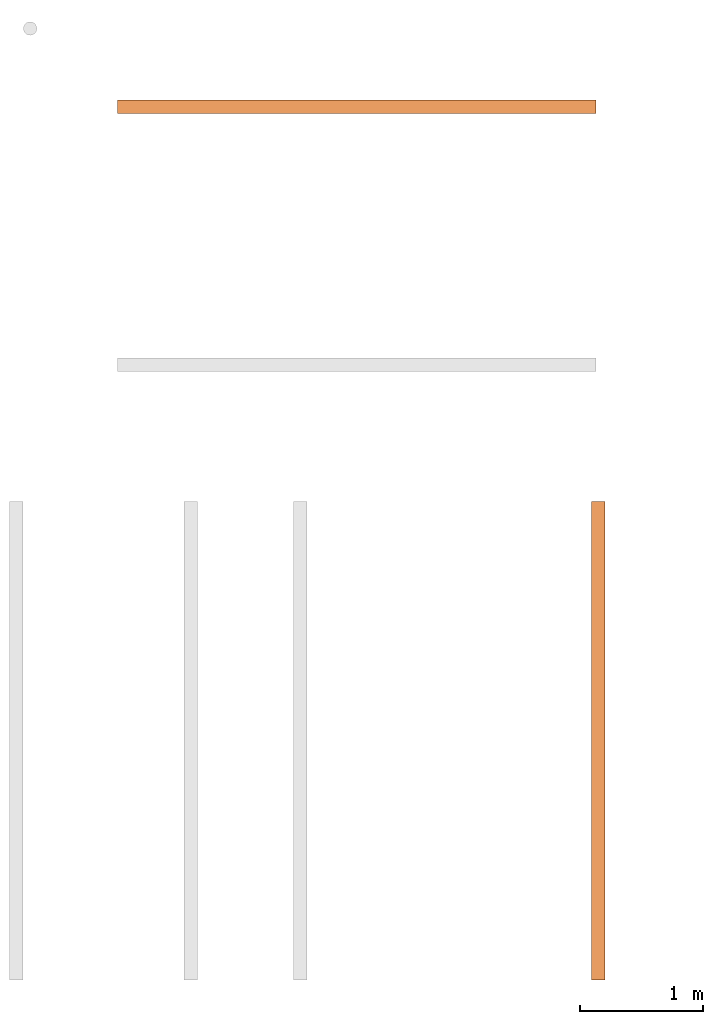
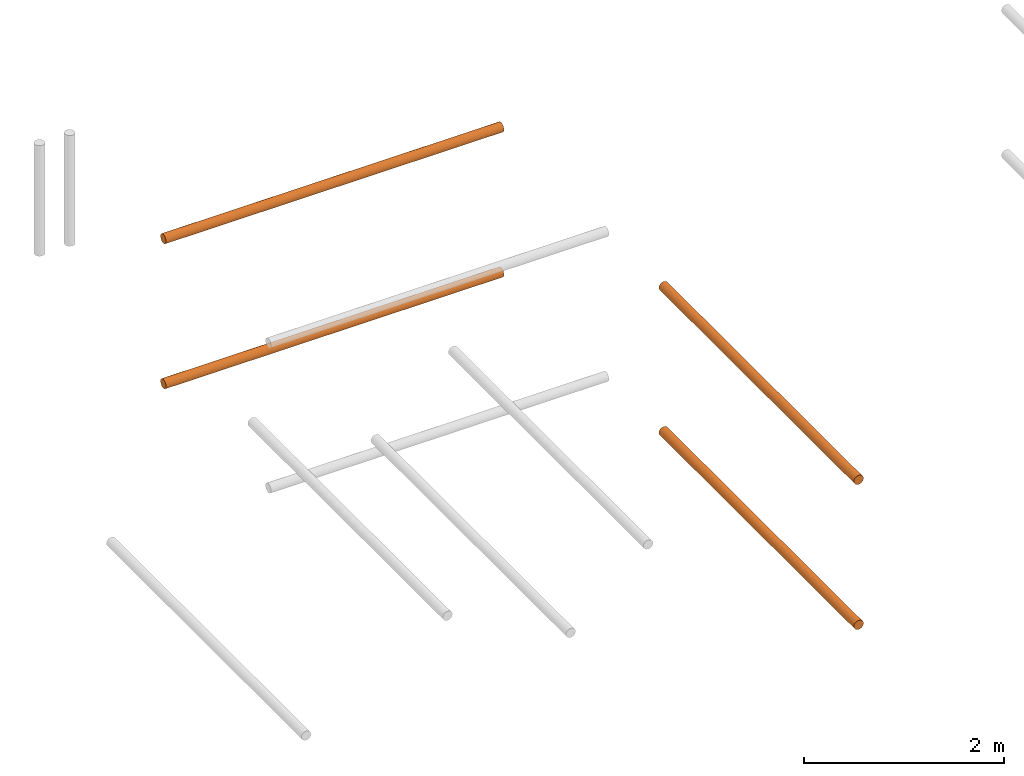
# One storey, part 4 of 5: 4 proxies.
"""IFC2X3 building model written with IfcOpenShell, lengths in metres."""

from ifc_helpers import new_model, entity, si_unit, converted_unit, frame, origin, place, context, subcontext, project, spatial, faceted_brep, material, element, save


model = new_model("IFC2X3")

# Units and contexts
model_context = context("Model", 3, precision=1e-05, world=origin())
body_context = subcontext(model_context, "Body", "Model", "MODEL_VIEW")
ifc_project = project(units=[si_unit("LENGTHUNIT", "METRE"), si_unit("AREAUNIT", "SQUARE_METRE"), si_unit("VOLUMEUNIT", "CUBIC_METRE"), converted_unit("PLANEANGLEUNIT", "DEGREE", entity("IfcPlaneAngleMeasure", 0.0174532925199433), si_unit("PLANEANGLEUNIT", "RADIAN"), dimensions=[0, 0, 0, 0, 0, 0, 0])], contexts=[model_context])

# Site, building, storey
site_placement = place(None, frame((2.0, 7.0, 6.0)))
site = spatial("IfcSite", under=ifc_project, at=site_placement, CompositionType="ELEMENT")
building_placement = place(site_placement, origin())
building = spatial("IfcBuilding", under=site, at=building_placement, Name="de", CompositionType="ELEMENT")
storey_placement = place(building_placement, frame((0.0, 0.0, 4.0)))
storey = spatial("IfcBuildingStorey", under=building, at=storey_placement, CompositionType="ELEMENT", Elevation=4.0)

# Proxies
ifc_material_1 = material()
proxy_1_placement = place(storey_placement, frame((2.371390691454128, 2.273736754432321e-16, 2.833089238362359)))
element("IfcBuildingElementProxy", 1, at=proxy_1_placement, inside=storey, material=ifc_material_1, context=body_context, shape_type="Brep", body=[
    faceted_brep([(0.11, 0.0, 0.05500000000000001), (0.1081259204458988, 0.0, 0.04076495251936138), (0.1026313972081441, 0.0, 0.02750000000000001), (0.09389087296526015, 0.0, 0.01610912703473991), (0.08250000000000002, 0.0, 0.007368602791855885), (0.06923504748063866, 0.0, 0.00187407955410125), (0.05500000000000003, 0.0, 0.0), (0.0407649525193614, 0.0, 0.001874079554101236), (0.02750000000000004, 0.0, 0.007368602791855849), (0.01610912703473991, 0.0, 0.01610912703473987), (0.007368602791855913, 0.0, 0.02749999999999994), (0.001874079554101257, 0.0, 0.04076495251936132), (0.0, 0.0, 0.05499999999999995), (0.001874079554101236, 0.0, 0.06923504748063862), (0.007368602791855849, 0.0, 0.08249999999999996), (0.01610912703473984, 0.0, 0.09389087296526008), (0.02749999999999994, 0.0, 0.1026313972081441), (0.04076495251936132, 0.0, 0.1081259204458988), (0.055, 0.0, 0.11), (0.06923504748063865, 0.0, 0.1081259204458988), (0.0825, 0.0, 0.1026313972081441), (0.09389087296526012, 0.0, 0.09389087296526012), (0.1026313972081441, 0.0, 0.0825), (0.1081259204458988, 0.0, 0.06923504748063866), (0.11, 3.9, 0.055), (0.1081259204458988, 3.9, 0.06923504748063866), (0.1026313972081441, 3.9, 0.0825), (0.09389087296526012, 3.9, 0.09389087296526012), (0.0825, 3.9, 0.1026313972081441), (0.06923504748063865, 3.9, 0.1081259204458988), (0.055, 3.9, 0.11), (0.04076495251936132, 3.9, 0.1081259204458988), (0.02749999999999994, 3.9, 0.1026313972081441), (0.01610912703473984, 3.9, 0.09389087296526008), (0.007368602791855849, 3.9, 0.08249999999999996), (0.001874079554101236, 3.9, 0.06923504748063862), (0.0, 3.9, 0.05499999999999995), (0.001874079554101257, 3.9, 0.04076495251936132), (0.007368602791855913, 3.9, 0.02749999999999994), (0.01610912703473991, 3.9, 0.01610912703473987), (0.02750000000000004, 3.9, 0.007368602791855849), (0.0407649525193614, 3.9, 0.001874079554101236), (0.05500000000000003, 3.9, 0.0), (0.06923504748063866, 3.9, 0.00187407955410125), (0.08250000000000002, 3.9, 0.007368602791855885), (0.09389087296526015, 3.9, 0.01610912703473991), (0.1026313972081441, 3.9, 0.02750000000000001), (0.1081259204458988, 3.9, 0.04076495251936138), (0.055, 3.9, 0.11), (0.055, 0.0, 0.11), (0.04076495251936132, 0.0, 0.1081259204458988), (0.04076495251936132, 3.9, 0.1081259204458988), (0.04076495251936132, 3.9, 0.1081259204458988), (0.04076495251936132, 0.0, 0.1081259204458988), (0.02749999999999994, 0.0, 0.1026313972081441), (0.02749999999999994, 3.9, 0.1026313972081441), (0.02749999999999994, 3.9, 0.1026313972081441), (0.02749999999999994, 0.0, 0.1026313972081441), (0.01610912703473984, 0.0, 0.09389087296526008), (0.01610912703473984, 3.9, 0.09389087296526008), (0.01610912703473984, 3.9, 0.09389087296526008), (0.01610912703473984, 0.0, 0.09389087296526008), (0.007368602791855849, 0.0, 0.08249999999999996), (0.007368602791855849, 3.9, 0.08249999999999996), (0.007368602791855849, 3.9, 0.08249999999999996), (0.007368602791855849, 0.0, 0.08249999999999996), (0.001874079554101236, 0.0, 0.06923504748063862), (0.001874079554101236, 3.9, 0.06923504748063862), (0.001874079554101236, 3.9, 0.06923504748063862), (0.001874079554101236, 0.0, 0.06923504748063862), (0.0, 0.0, 0.05499999999999995), (0.0, 3.9, 0.05499999999999995), (0.0, 3.9, 0.05499999999999995), (0.0, 0.0, 0.05499999999999995), (0.001874079554101257, 0.0, 0.04076495251936132), (0.001874079554101257, 3.9, 0.04076495251936132), (0.001874079554101257, 3.9, 0.04076495251936132), (0.001874079554101257, 0.0, 0.04076495251936132), (0.007368602791855913, 0.0, 0.02749999999999994), (0.007368602791855913, 3.9, 0.02749999999999994), (0.007368602791855913, 3.9, 0.02749999999999994), (0.007368602791855913, 0.0, 0.02749999999999994), (0.01610912703473991, 0.0, 0.01610912703473987), (0.01610912703473991, 3.9, 0.01610912703473987), (0.01610912703473991, 3.9, 0.01610912703473987), (0.01610912703473991, 0.0, 0.01610912703473987), (0.02750000000000004, 0.0, 0.007368602791855849), (0.02750000000000004, 3.9, 0.007368602791855849), (0.02750000000000004, 3.9, 0.007368602791855849), (0.02750000000000004, 0.0, 0.007368602791855849), (0.0407649525193614, 0.0, 0.001874079554101236), (0.0407649525193614, 3.9, 0.001874079554101236), (0.0407649525193614, 3.9, 0.001874079554101236), (0.0407649525193614, 0.0, 0.001874079554101236), (0.05500000000000003, 0.0, 0.0), (0.05500000000000003, 3.9, 0.0), (0.05500000000000003, 3.9, 0.0), (0.05500000000000003, 0.0, 0.0), (0.06923504748063866, 0.0, 0.00187407955410125), (0.06923504748063866, 3.9, 0.00187407955410125), (0.06923504748063866, 3.9, 0.00187407955410125), (0.06923504748063866, 0.0, 0.00187407955410125), (0.08250000000000002, 0.0, 0.007368602791855885), (0.08250000000000002, 3.9, 0.007368602791855885), (0.08250000000000002, 3.9, 0.007368602791855885), (0.08250000000000002, 0.0, 0.007368602791855885), (0.09389087296526015, 0.0, 0.01610912703473991), (0.09389087296526015, 3.9, 0.01610912703473991), (0.09389087296526015, 3.9, 0.01610912703473991), (0.09389087296526015, 0.0, 0.01610912703473991), (0.1026313972081441, 0.0, 0.02750000000000001), (0.1026313972081441, 3.9, 0.02750000000000001), (0.1026313972081441, 3.9, 0.02750000000000001), (0.1026313972081441, 0.0, 0.02750000000000001), (0.1081259204458988, 0.0, 0.04076495251936138), (0.1081259204458988, 3.9, 0.04076495251936138), (0.1081259204458988, 3.9, 0.04076495251936138), (0.1081259204458988, 0.0, 0.04076495251936138), (0.11, 0.0, 0.05500000000000001), (0.11, 3.9, 0.055), (0.11, 3.9, 0.055), (0.11, 0.0, 0.05500000000000001), (0.1081259204458988, 0.0, 0.06923504748063866), (0.1081259204458988, 3.9, 0.06923504748063866), (0.1081259204458988, 3.9, 0.06923504748063866), (0.1081259204458988, 0.0, 0.06923504748063866), (0.1026313972081441, 0.0, 0.0825), (0.1026313972081441, 3.9, 0.0825), (0.1026313972081441, 3.9, 0.0825), (0.1026313972081441, 0.0, 0.0825), (0.09389087296526012, 0.0, 0.09389087296526012), (0.09389087296526012, 3.9, 0.09389087296526012), (0.09389087296526012, 3.9, 0.09389087296526012), (0.09389087296526012, 0.0, 0.09389087296526012), (0.0825, 0.0, 0.1026313972081441), (0.0825, 3.9, 0.1026313972081441), (0.0825, 3.9, 0.1026313972081441), (0.0825, 0.0, 0.1026313972081441), (0.06923504748063865, 0.0, 0.1081259204458988), (0.06923504748063865, 3.9, 0.1081259204458988), (0.06923504748063865, 3.9, 0.1081259204458988), (0.06923504748063865, 0.0, 0.1081259204458988), (0.055, 0.0, 0.11), (0.055, 3.9, 0.11)], [[[0, 1, 2, 3, 4, 5, 6, 7, 8, 9, 10, 11, 12, 13, 14, 15, 16, 17, 18, 19, 20, 21, 22, 23]], [[24, 25, 26, 27, 28, 29, 30, 31, 32, 33, 34, 35, 36, 37, 38, 39, 40, 41, 42, 43, 44, 45, 46, 47]], [[48, 49, 50, 51]], [[52, 53, 54, 55]], [[56, 57, 58, 59]], [[60, 61, 62, 63]], [[64, 65, 66, 67]], [[68, 69, 70, 71]], [[72, 73, 74, 75]], [[76, 77, 78, 79]], [[80, 81, 82, 83]], [[84, 85, 86, 87]], [[88, 89, 90, 91]], [[92, 93, 94, 95]], [[96, 97, 98, 99]], [[100, 101, 102, 103]], [[104, 105, 106, 107]], [[108, 109, 110, 111]], [[112, 113, 114, 115]], [[116, 117, 118, 119]], [[120, 121, 122, 123]], [[124, 125, 126, 127]], [[128, 129, 130, 131]], [[132, 133, 134, 135]], [[136, 137, 138, 139]], [[140, 141, 142, 143]]], orient=[[False], [False], [False], [False], [False], [False], [False], [False], [False], [False], [False], [False], [False], [False], [False], [False], [False], [False], [False], [False], [False], [False], [False], [False], [False], [False]]),
])
ifc_material_2 = material()
proxy_2_placement = place(storey_placement, frame((-1.492756561293123, 7.060484249084253, 2.833089238362359)))
element("IfcBuildingElementProxy", 2, at=proxy_2_placement, inside=storey, material=ifc_material_2, context=body_context, shape_type="Brep", body=[
    faceted_brep([(3.9, 0.1099999999999998, 0.05500000000000001), (3.9, 0.1081259204458985, 0.04076495251936138), (3.9, 0.1026313972081439, 0.02750000000000001), (3.9, 0.09389087296525989, 0.01610912703473991), (3.9, 0.08249999999999977, 0.007368602791855885), (3.9, 0.06923504748063844, 0.001874079554101257), (3.9, 0.05499999999999979, 0.0), (3.9, 0.04076495251936117, 0.001874079554101236), (3.9, 0.02749999999999982, 0.007368602791855842), (3.9, 0.0161091270347397, 0.01610912703473985), (3.9, 0.007368602791855672, 0.02749999999999994), (3.9, 0.001874079554101023, 0.04076495251936132), (3.9, -2.344791028008331e-16, 0.05499999999999995), (3.9, 0.001874079554100987, 0.06923504748063858), (3.9, 0.007368602791855615, 0.08249999999999996), (3.9, 0.0161091270347396, 0.09389087296526008), (3.9, 0.0274999999999997, 0.1026313972081441), (3.9, 0.04076495251936108, 0.1081259204458988), (3.9, 0.05499999999999976, 0.11), (3.9, 0.0692350474806384, 0.1081259204458988), (3.9, 0.08249999999999974, 0.1026313972081441), (3.9, 0.09389087296525987, 0.09389087296526012), (3.9, 0.1026313972081439, 0.0825), (3.9, 0.1081259204458985, 0.06923504748063866), (0.0, 0.1100000000000002, 0.055), (0.0, 0.108125920445899, 0.06923504748063866), (0.0, 0.1026313972081444, 0.0825), (0.0, 0.09389087296526034, 0.09389087296526012), (0.0, 0.08250000000000023, 0.1026313972081441), (0.0, 0.06923504748063888, 0.1081259204458988), (0.0, 0.05500000000000024, 0.11), (0.0, 0.04076495251936155, 0.1081259204458988), (0.0, 0.02750000000000017, 0.1026313972081441), (0.0, 0.01610912703474008, 0.09389087296526008), (0.0, 0.007368602791856091, 0.08249999999999996), (0.0, 0.001874079554101464, 0.06923504748063858), (0.0, 2.415845301584341e-16, 0.05499999999999995), (0.0, 0.001874079554101499, 0.04076495251936132), (0.0, 0.007368602791856148, 0.02749999999999994), (0.0, 0.01610912703474017, 0.01610912703473985), (0.0, 0.0275000000000003, 0.007368602791855842), (0.0, 0.04076495251936164, 0.001874079554101236), (0.0, 0.05500000000000027, 0.0), (0.0, 0.06923504748063893, 0.001874079554101257), (0.0, 0.08250000000000025, 0.007368602791855885), (0.0, 0.09389087296526037, 0.01610912703473991), (0.0, 0.1026313972081444, 0.02750000000000001), (0.0, 0.108125920445899, 0.04076495251936138), (0.0, 0.05500000000000024, 0.11), (3.9, 0.05499999999999976, 0.11), (3.9, 0.04076495251936108, 0.1081259204458988), (0.0, 0.04076495251936155, 0.1081259204458988), (0.0, 0.04076495251936155, 0.1081259204458988), (3.9, 0.04076495251936108, 0.1081259204458988), (3.9, 0.0274999999999997, 0.1026313972081441), (0.0, 0.02750000000000017, 0.1026313972081441), (0.0, 0.02750000000000017, 0.1026313972081441), (3.9, 0.0274999999999997, 0.1026313972081441), (3.9, 0.0161091270347396, 0.09389087296526008), (0.0, 0.01610912703474008, 0.09389087296526008), (0.0, 0.01610912703474008, 0.09389087296526008), (3.9, 0.0161091270347396, 0.09389087296526008), (3.9, 0.007368602791855615, 0.08249999999999996), (0.0, 0.007368602791856091, 0.08249999999999996), (0.0, 0.007368602791856091, 0.08249999999999996), (3.9, 0.007368602791855615, 0.08249999999999996), (3.9, 0.001874079554100987, 0.06923504748063858), (0.0, 0.001874079554101464, 0.06923504748063858), (0.0, 0.001874079554101464, 0.06923504748063858), (3.9, 0.001874079554100987, 0.06923504748063858), (3.9, -2.344791028008331e-16, 0.05499999999999995), (0.0, 2.415845301584341e-16, 0.05499999999999995), (0.0, 2.415845301584341e-16, 0.05499999999999995), (3.9, -2.344791028008331e-16, 0.05499999999999995), (3.9, 0.001874079554101023, 0.04076495251936132), (0.0, 0.001874079554101499, 0.04076495251936132), (0.0, 0.001874079554101499, 0.04076495251936132), (3.9, 0.001874079554101023, 0.04076495251936132), (3.9, 0.007368602791855672, 0.02749999999999994), (0.0, 0.007368602791856148, 0.02749999999999994), (0.0, 0.007368602791856148, 0.02749999999999994), (3.9, 0.007368602791855672, 0.02749999999999994), (3.9, 0.0161091270347397, 0.01610912703473985), (0.0, 0.01610912703474017, 0.01610912703473985), (0.0, 0.01610912703474017, 0.01610912703473985), (3.9, 0.0161091270347397, 0.01610912703473985), (3.9, 0.02749999999999982, 0.007368602791855842), (0.0, 0.0275000000000003, 0.007368602791855842), (0.0, 0.0275000000000003, 0.007368602791855842), (3.9, 0.02749999999999982, 0.007368602791855842), (3.9, 0.04076495251936117, 0.001874079554101236), (0.0, 0.04076495251936164, 0.001874079554101236), (0.0, 0.04076495251936164, 0.001874079554101236), (3.9, 0.04076495251936117, 0.001874079554101236), (3.9, 0.05499999999999979, 0.0), (0.0, 0.05500000000000027, 0.0), (0.0, 0.05500000000000027, 0.0), (3.9, 0.05499999999999979, 0.0), (3.9, 0.06923504748063844, 0.001874079554101257), (0.0, 0.06923504748063893, 0.001874079554101257), (0.0, 0.06923504748063893, 0.001874079554101257), (3.9, 0.06923504748063844, 0.001874079554101257), (3.9, 0.08249999999999977, 0.007368602791855885), (0.0, 0.08250000000000025, 0.007368602791855885), (0.0, 0.08250000000000025, 0.007368602791855885), (3.9, 0.08249999999999977, 0.007368602791855885), (3.9, 0.09389087296525989, 0.01610912703473991), (0.0, 0.09389087296526037, 0.01610912703473991), (0.0, 0.09389087296526037, 0.01610912703473991), (3.9, 0.09389087296525989, 0.01610912703473991), (3.9, 0.1026313972081439, 0.02750000000000001), (0.0, 0.1026313972081444, 0.02750000000000001), (0.0, 0.1026313972081444, 0.02750000000000001), (3.9, 0.1026313972081439, 0.02750000000000001), (3.9, 0.1081259204458985, 0.04076495251936138), (0.0, 0.108125920445899, 0.04076495251936138), (0.0, 0.108125920445899, 0.04076495251936138), (3.9, 0.1081259204458985, 0.04076495251936138), (3.9, 0.1099999999999998, 0.05500000000000001), (0.0, 0.1100000000000002, 0.055), (0.0, 0.1100000000000002, 0.055), (3.9, 0.1099999999999998, 0.05500000000000001), (3.9, 0.1081259204458985, 0.06923504748063866), (0.0, 0.108125920445899, 0.06923504748063866), (0.0, 0.108125920445899, 0.06923504748063866), (3.9, 0.1081259204458985, 0.06923504748063866), (3.9, 0.1026313972081439, 0.0825), (0.0, 0.1026313972081444, 0.0825), (0.0, 0.1026313972081444, 0.0825), (3.9, 0.1026313972081439, 0.0825), (3.9, 0.09389087296525987, 0.09389087296526012), (0.0, 0.09389087296526034, 0.09389087296526012), (0.0, 0.09389087296526034, 0.09389087296526012), (3.9, 0.09389087296525987, 0.09389087296526012), (3.9, 0.08249999999999974, 0.1026313972081441), (0.0, 0.08250000000000023, 0.1026313972081441), (0.0, 0.08250000000000023, 0.1026313972081441), (3.9, 0.08249999999999974, 0.1026313972081441), (3.9, 0.0692350474806384, 0.1081259204458988), (0.0, 0.06923504748063888, 0.1081259204458988), (0.0, 0.06923504748063888, 0.1081259204458988), (3.9, 0.0692350474806384, 0.1081259204458988), (3.9, 0.05499999999999976, 0.11), (0.0, 0.05500000000000024, 0.11)], [[[0, 1, 2, 3, 4, 5, 6, 7, 8, 9, 10, 11, 12, 13, 14, 15, 16, 17, 18, 19, 20, 21, 22, 23]], [[24, 25, 26, 27, 28, 29, 30, 31, 32, 33, 34, 35, 36, 37, 38, 39, 40, 41, 42, 43, 44, 45, 46, 47]], [[48, 49, 50, 51]], [[52, 53, 54, 55]], [[56, 57, 58, 59]], [[60, 61, 62, 63]], [[64, 65, 66, 67]], [[68, 69, 70, 71]], [[72, 73, 74, 75]], [[76, 77, 78, 79]], [[80, 81, 82, 83]], [[84, 85, 86, 87]], [[88, 89, 90, 91]], [[92, 93, 94, 95]], [[96, 97, 98, 99]], [[100, 101, 102, 103]], [[104, 105, 106, 107]], [[108, 109, 110, 111]], [[112, 113, 114, 115]], [[116, 117, 118, 119]], [[120, 121, 122, 123]], [[124, 125, 126, 127]], [[128, 129, 130, 131]], [[132, 133, 134, 135]], [[136, 137, 138, 139]], [[140, 141, 142, 143]]], orient=[[False], [False], [False], [False], [False], [False], [False], [False], [False], [False], [False], [False], [False], [False], [False], [False], [False], [False], [False], [False], [False], [False], [False], [False], [False], [False]]),
])
ifc_material_3 = material()
proxy_3_placement = place(storey_placement, frame((2.371390691454128, 2.273736754432321e-16, 1.063089238362359)))
element("IfcBuildingElementProxy", 3, at=proxy_3_placement, inside=storey, material=ifc_material_3, context=body_context, shape_type="Brep", body=[
    faceted_brep([(0.11, 0.0, 0.05500000000000001), (0.1081259204458988, 0.0, 0.04076495251936138), (0.1026313972081441, 0.0, 0.02750000000000001), (0.09389087296526015, 0.0, 0.01610912703473991), (0.08250000000000002, 0.0, 0.007368602791855885), (0.06923504748063866, 0.0, 0.00187407955410125), (0.05500000000000003, 0.0, 0.0), (0.0407649525193614, 0.0, 0.001874079554101236), (0.02750000000000004, 0.0, 0.007368602791855849), (0.01610912703473991, 0.0, 0.01610912703473987), (0.007368602791855913, 0.0, 0.02749999999999994), (0.001874079554101257, 0.0, 0.04076495251936132), (0.0, 0.0, 0.05499999999999995), (0.001874079554101236, 0.0, 0.06923504748063862), (0.007368602791855849, 0.0, 0.08249999999999996), (0.01610912703473984, 0.0, 0.09389087296526008), (0.02749999999999994, 0.0, 0.1026313972081441), (0.04076495251936132, 0.0, 0.1081259204458988), (0.055, 0.0, 0.11), (0.06923504748063865, 0.0, 0.1081259204458988), (0.0825, 0.0, 0.1026313972081441), (0.09389087296526012, 0.0, 0.09389087296526012), (0.1026313972081441, 0.0, 0.0825), (0.1081259204458988, 0.0, 0.06923504748063866), (0.11, 3.9, 0.055), (0.1081259204458988, 3.9, 0.06923504748063866), (0.1026313972081441, 3.9, 0.0825), (0.09389087296526012, 3.9, 0.09389087296526012), (0.0825, 3.9, 0.1026313972081441), (0.06923504748063865, 3.9, 0.1081259204458988), (0.055, 3.9, 0.11), (0.04076495251936132, 3.9, 0.1081259204458988), (0.02749999999999994, 3.9, 0.1026313972081441), (0.01610912703473984, 3.9, 0.09389087296526008), (0.007368602791855849, 3.9, 0.08249999999999996), (0.001874079554101236, 3.9, 0.06923504748063862), (0.0, 3.9, 0.05499999999999995), (0.001874079554101257, 3.9, 0.04076495251936132), (0.007368602791855913, 3.9, 0.02749999999999994), (0.01610912703473991, 3.9, 0.01610912703473987), (0.02750000000000004, 3.9, 0.007368602791855849), (0.0407649525193614, 3.9, 0.001874079554101236), (0.05500000000000003, 3.9, 0.0), (0.06923504748063866, 3.9, 0.00187407955410125), (0.08250000000000002, 3.9, 0.007368602791855885), (0.09389087296526015, 3.9, 0.01610912703473991), (0.1026313972081441, 3.9, 0.02750000000000001), (0.1081259204458988, 3.9, 0.04076495251936138), (0.055, 3.9, 0.11), (0.055, 0.0, 0.11), (0.04076495251936132, 0.0, 0.1081259204458988), (0.04076495251936132, 3.9, 0.1081259204458988), (0.04076495251936132, 3.9, 0.1081259204458988), (0.04076495251936132, 0.0, 0.1081259204458988), (0.02749999999999994, 0.0, 0.1026313972081441), (0.02749999999999994, 3.9, 0.1026313972081441), (0.02749999999999994, 3.9, 0.1026313972081441), (0.02749999999999994, 0.0, 0.1026313972081441), (0.01610912703473984, 0.0, 0.09389087296526008), (0.01610912703473984, 3.9, 0.09389087296526008), (0.01610912703473984, 3.9, 0.09389087296526008), (0.01610912703473984, 0.0, 0.09389087296526008), (0.007368602791855849, 0.0, 0.08249999999999996), (0.007368602791855849, 3.9, 0.08249999999999996), (0.007368602791855849, 3.9, 0.08249999999999996), (0.007368602791855849, 0.0, 0.08249999999999996), (0.001874079554101236, 0.0, 0.06923504748063862), (0.001874079554101236, 3.9, 0.06923504748063862), (0.001874079554101236, 3.9, 0.06923504748063862), (0.001874079554101236, 0.0, 0.06923504748063862), (0.0, 0.0, 0.05499999999999995), (0.0, 3.9, 0.05499999999999995), (0.0, 3.9, 0.05499999999999995), (0.0, 0.0, 0.05499999999999995), (0.001874079554101257, 0.0, 0.04076495251936132), (0.001874079554101257, 3.9, 0.04076495251936132), (0.001874079554101257, 3.9, 0.04076495251936132), (0.001874079554101257, 0.0, 0.04076495251936132), (0.007368602791855913, 0.0, 0.02749999999999994), (0.007368602791855913, 3.9, 0.02749999999999994), (0.007368602791855913, 3.9, 0.02749999999999994), (0.007368602791855913, 0.0, 0.02749999999999994), (0.01610912703473991, 0.0, 0.01610912703473987), (0.01610912703473991, 3.9, 0.01610912703473987), (0.01610912703473991, 3.9, 0.01610912703473987), (0.01610912703473991, 0.0, 0.01610912703473987), (0.02750000000000004, 0.0, 0.007368602791855849), (0.02750000000000004, 3.9, 0.007368602791855849), (0.02750000000000004, 3.9, 0.007368602791855849), (0.02750000000000004, 0.0, 0.007368602791855849), (0.0407649525193614, 0.0, 0.001874079554101236), (0.0407649525193614, 3.9, 0.001874079554101236), (0.0407649525193614, 3.9, 0.001874079554101236), (0.0407649525193614, 0.0, 0.001874079554101236), (0.05500000000000003, 0.0, 0.0), (0.05500000000000003, 3.9, 0.0), (0.05500000000000003, 3.9, 0.0), (0.05500000000000003, 0.0, 0.0), (0.06923504748063866, 0.0, 0.00187407955410125), (0.06923504748063866, 3.9, 0.00187407955410125), (0.06923504748063866, 3.9, 0.00187407955410125), (0.06923504748063866, 0.0, 0.00187407955410125), (0.08250000000000002, 0.0, 0.007368602791855885), (0.08250000000000002, 3.9, 0.007368602791855885), (0.08250000000000002, 3.9, 0.007368602791855885), (0.08250000000000002, 0.0, 0.007368602791855885), (0.09389087296526015, 0.0, 0.01610912703473991), (0.09389087296526015, 3.9, 0.01610912703473991), (0.09389087296526015, 3.9, 0.01610912703473991), (0.09389087296526015, 0.0, 0.01610912703473991), (0.1026313972081441, 0.0, 0.02750000000000001), (0.1026313972081441, 3.9, 0.02750000000000001), (0.1026313972081441, 3.9, 0.02750000000000001), (0.1026313972081441, 0.0, 0.02750000000000001), (0.1081259204458988, 0.0, 0.04076495251936138), (0.1081259204458988, 3.9, 0.04076495251936138), (0.1081259204458988, 3.9, 0.04076495251936138), (0.1081259204458988, 0.0, 0.04076495251936138), (0.11, 0.0, 0.05500000000000001), (0.11, 3.9, 0.055), (0.11, 3.9, 0.055), (0.11, 0.0, 0.05500000000000001), (0.1081259204458988, 0.0, 0.06923504748063866), (0.1081259204458988, 3.9, 0.06923504748063866), (0.1081259204458988, 3.9, 0.06923504748063866), (0.1081259204458988, 0.0, 0.06923504748063866), (0.1026313972081441, 0.0, 0.0825), (0.1026313972081441, 3.9, 0.0825), (0.1026313972081441, 3.9, 0.0825), (0.1026313972081441, 0.0, 0.0825), (0.09389087296526012, 0.0, 0.09389087296526012), (0.09389087296526012, 3.9, 0.09389087296526012), (0.09389087296526012, 3.9, 0.09389087296526012), (0.09389087296526012, 0.0, 0.09389087296526012), (0.0825, 0.0, 0.1026313972081441), (0.0825, 3.9, 0.1026313972081441), (0.0825, 3.9, 0.1026313972081441), (0.0825, 0.0, 0.1026313972081441), (0.06923504748063865, 0.0, 0.1081259204458988), (0.06923504748063865, 3.9, 0.1081259204458988), (0.06923504748063865, 3.9, 0.1081259204458988), (0.06923504748063865, 0.0, 0.1081259204458988), (0.055, 0.0, 0.11), (0.055, 3.9, 0.11)], [[[0, 1, 2, 3, 4, 5, 6, 7, 8, 9, 10, 11, 12, 13, 14, 15, 16, 17, 18, 19, 20, 21, 22, 23]], [[24, 25, 26, 27, 28, 29, 30, 31, 32, 33, 34, 35, 36, 37, 38, 39, 40, 41, 42, 43, 44, 45, 46, 47]], [[48, 49, 50, 51]], [[52, 53, 54, 55]], [[56, 57, 58, 59]], [[60, 61, 62, 63]], [[64, 65, 66, 67]], [[68, 69, 70, 71]], [[72, 73, 74, 75]], [[76, 77, 78, 79]], [[80, 81, 82, 83]], [[84, 85, 86, 87]], [[88, 89, 90, 91]], [[92, 93, 94, 95]], [[96, 97, 98, 99]], [[100, 101, 102, 103]], [[104, 105, 106, 107]], [[108, 109, 110, 111]], [[112, 113, 114, 115]], [[116, 117, 118, 119]], [[120, 121, 122, 123]], [[124, 125, 126, 127]], [[128, 129, 130, 131]], [[132, 133, 134, 135]], [[136, 137, 138, 139]], [[140, 141, 142, 143]]], orient=[[False], [False], [False], [False], [False], [False], [False], [False], [False], [False], [False], [False], [False], [False], [False], [False], [False], [False], [False], [False], [False], [False], [False], [False], [False], [False]]),
])
ifc_material_4 = material()
proxy_4_placement = place(storey_placement, frame((-1.492756561293123, 7.060484249084253, 1.063089238362359)))
element("IfcBuildingElementProxy", 4, at=proxy_4_placement, inside=storey, material=ifc_material_4, context=body_context, shape_type="Brep", body=[
    faceted_brep([(3.9, 0.1099999999999998, 0.05500000000000001), (3.9, 0.1081259204458985, 0.04076495251936138), (3.9, 0.1026313972081439, 0.02750000000000001), (3.9, 0.09389087296525989, 0.01610912703473991), (3.9, 0.08249999999999977, 0.007368602791855885), (3.9, 0.06923504748063844, 0.001874079554101257), (3.9, 0.05499999999999979, 0.0), (3.9, 0.04076495251936117, 0.001874079554101236), (3.9, 0.02749999999999982, 0.007368602791855842), (3.9, 0.0161091270347397, 0.01610912703473985), (3.9, 0.007368602791855672, 0.02749999999999994), (3.9, 0.001874079554101023, 0.04076495251936132), (3.9, -2.344791028008331e-16, 0.05499999999999995), (3.9, 0.001874079554100987, 0.06923504748063858), (3.9, 0.007368602791855615, 0.08249999999999996), (3.9, 0.0161091270347396, 0.09389087296526008), (3.9, 0.0274999999999997, 0.1026313972081441), (3.9, 0.04076495251936108, 0.1081259204458988), (3.9, 0.05499999999999976, 0.11), (3.9, 0.0692350474806384, 0.1081259204458988), (3.9, 0.08249999999999974, 0.1026313972081441), (3.9, 0.09389087296525987, 0.09389087296526012), (3.9, 0.1026313972081439, 0.0825), (3.9, 0.1081259204458985, 0.06923504748063866), (0.0, 0.1100000000000002, 0.055), (0.0, 0.108125920445899, 0.06923504748063866), (0.0, 0.1026313972081444, 0.0825), (0.0, 0.09389087296526034, 0.09389087296526012), (0.0, 0.08250000000000023, 0.1026313972081441), (0.0, 0.06923504748063888, 0.1081259204458988), (0.0, 0.05500000000000024, 0.11), (0.0, 0.04076495251936155, 0.1081259204458988), (0.0, 0.02750000000000017, 0.1026313972081441), (0.0, 0.01610912703474008, 0.09389087296526008), (0.0, 0.007368602791856091, 0.08249999999999996), (0.0, 0.001874079554101464, 0.06923504748063858), (0.0, 2.415845301584341e-16, 0.05499999999999995), (0.0, 0.001874079554101499, 0.04076495251936132), (0.0, 0.007368602791856148, 0.02749999999999994), (0.0, 0.01610912703474017, 0.01610912703473985), (0.0, 0.0275000000000003, 0.007368602791855842), (0.0, 0.04076495251936164, 0.001874079554101236), (0.0, 0.05500000000000027, 0.0), (0.0, 0.06923504748063893, 0.001874079554101257), (0.0, 0.08250000000000025, 0.007368602791855885), (0.0, 0.09389087296526037, 0.01610912703473991), (0.0, 0.1026313972081444, 0.02750000000000001), (0.0, 0.108125920445899, 0.04076495251936138), (0.0, 0.05500000000000024, 0.11), (3.9, 0.05499999999999976, 0.11), (3.9, 0.04076495251936108, 0.1081259204458988), (0.0, 0.04076495251936155, 0.1081259204458988), (0.0, 0.04076495251936155, 0.1081259204458988), (3.9, 0.04076495251936108, 0.1081259204458988), (3.9, 0.0274999999999997, 0.1026313972081441), (0.0, 0.02750000000000017, 0.1026313972081441), (0.0, 0.02750000000000017, 0.1026313972081441), (3.9, 0.0274999999999997, 0.1026313972081441), (3.9, 0.0161091270347396, 0.09389087296526008), (0.0, 0.01610912703474008, 0.09389087296526008), (0.0, 0.01610912703474008, 0.09389087296526008), (3.9, 0.0161091270347396, 0.09389087296526008), (3.9, 0.007368602791855615, 0.08249999999999996), (0.0, 0.007368602791856091, 0.08249999999999996), (0.0, 0.007368602791856091, 0.08249999999999996), (3.9, 0.007368602791855615, 0.08249999999999996), (3.9, 0.001874079554100987, 0.06923504748063858), (0.0, 0.001874079554101464, 0.06923504748063858), (0.0, 0.001874079554101464, 0.06923504748063858), (3.9, 0.001874079554100987, 0.06923504748063858), (3.9, -2.344791028008331e-16, 0.05499999999999995), (0.0, 2.415845301584341e-16, 0.05499999999999995), (0.0, 2.415845301584341e-16, 0.05499999999999995), (3.9, -2.344791028008331e-16, 0.05499999999999995), (3.9, 0.001874079554101023, 0.04076495251936132), (0.0, 0.001874079554101499, 0.04076495251936132), (0.0, 0.001874079554101499, 0.04076495251936132), (3.9, 0.001874079554101023, 0.04076495251936132), (3.9, 0.007368602791855672, 0.02749999999999994), (0.0, 0.007368602791856148, 0.02749999999999994), (0.0, 0.007368602791856148, 0.02749999999999994), (3.9, 0.007368602791855672, 0.02749999999999994), (3.9, 0.0161091270347397, 0.01610912703473985), (0.0, 0.01610912703474017, 0.01610912703473985), (0.0, 0.01610912703474017, 0.01610912703473985), (3.9, 0.0161091270347397, 0.01610912703473985), (3.9, 0.02749999999999982, 0.007368602791855842), (0.0, 0.0275000000000003, 0.007368602791855842), (0.0, 0.0275000000000003, 0.007368602791855842), (3.9, 0.02749999999999982, 0.007368602791855842), (3.9, 0.04076495251936117, 0.001874079554101236), (0.0, 0.04076495251936164, 0.001874079554101236), (0.0, 0.04076495251936164, 0.001874079554101236), (3.9, 0.04076495251936117, 0.001874079554101236), (3.9, 0.05499999999999979, 0.0), (0.0, 0.05500000000000027, 0.0), (0.0, 0.05500000000000027, 0.0), (3.9, 0.05499999999999979, 0.0), (3.9, 0.06923504748063844, 0.001874079554101257), (0.0, 0.06923504748063893, 0.001874079554101257), (0.0, 0.06923504748063893, 0.001874079554101257), (3.9, 0.06923504748063844, 0.001874079554101257), (3.9, 0.08249999999999977, 0.007368602791855885), (0.0, 0.08250000000000025, 0.007368602791855885), (0.0, 0.08250000000000025, 0.007368602791855885), (3.9, 0.08249999999999977, 0.007368602791855885), (3.9, 0.09389087296525989, 0.01610912703473991), (0.0, 0.09389087296526037, 0.01610912703473991), (0.0, 0.09389087296526037, 0.01610912703473991), (3.9, 0.09389087296525989, 0.01610912703473991), (3.9, 0.1026313972081439, 0.02750000000000001), (0.0, 0.1026313972081444, 0.02750000000000001), (0.0, 0.1026313972081444, 0.02750000000000001), (3.9, 0.1026313972081439, 0.02750000000000001), (3.9, 0.1081259204458985, 0.04076495251936138), (0.0, 0.108125920445899, 0.04076495251936138), (0.0, 0.108125920445899, 0.04076495251936138), (3.9, 0.1081259204458985, 0.04076495251936138), (3.9, 0.1099999999999998, 0.05500000000000001), (0.0, 0.1100000000000002, 0.055), (0.0, 0.1100000000000002, 0.055), (3.9, 0.1099999999999998, 0.05500000000000001), (3.9, 0.1081259204458985, 0.06923504748063866), (0.0, 0.108125920445899, 0.06923504748063866), (0.0, 0.108125920445899, 0.06923504748063866), (3.9, 0.1081259204458985, 0.06923504748063866), (3.9, 0.1026313972081439, 0.0825), (0.0, 0.1026313972081444, 0.0825), (0.0, 0.1026313972081444, 0.0825), (3.9, 0.1026313972081439, 0.0825), (3.9, 0.09389087296525987, 0.09389087296526012), (0.0, 0.09389087296526034, 0.09389087296526012), (0.0, 0.09389087296526034, 0.09389087296526012), (3.9, 0.09389087296525987, 0.09389087296526012), (3.9, 0.08249999999999974, 0.1026313972081441), (0.0, 0.08250000000000023, 0.1026313972081441), (0.0, 0.08250000000000023, 0.1026313972081441), (3.9, 0.08249999999999974, 0.1026313972081441), (3.9, 0.0692350474806384, 0.1081259204458988), (0.0, 0.06923504748063888, 0.1081259204458988), (0.0, 0.06923504748063888, 0.1081259204458988), (3.9, 0.0692350474806384, 0.1081259204458988), (3.9, 0.05499999999999976, 0.11), (0.0, 0.05500000000000024, 0.11)], [[[0, 1, 2, 3, 4, 5, 6, 7, 8, 9, 10, 11, 12, 13, 14, 15, 16, 17, 18, 19, 20, 21, 22, 23]], [[24, 25, 26, 27, 28, 29, 30, 31, 32, 33, 34, 35, 36, 37, 38, 39, 40, 41, 42, 43, 44, 45, 46, 47]], [[48, 49, 50, 51]], [[52, 53, 54, 55]], [[56, 57, 58, 59]], [[60, 61, 62, 63]], [[64, 65, 66, 67]], [[68, 69, 70, 71]], [[72, 73, 74, 75]], [[76, 77, 78, 79]], [[80, 81, 82, 83]], [[84, 85, 86, 87]], [[88, 89, 90, 91]], [[92, 93, 94, 95]], [[96, 97, 98, 99]], [[100, 101, 102, 103]], [[104, 105, 106, 107]], [[108, 109, 110, 111]], [[112, 113, 114, 115]], [[116, 117, 118, 119]], [[120, 121, 122, 123]], [[124, 125, 126, 127]], [[128, 129, 130, 131]], [[132, 133, 134, 135]], [[136, 137, 138, 139]], [[140, 141, 142, 143]]], orient=[[False], [False], [False], [False], [False], [False], [False], [False], [False], [False], [False], [False], [False], [False], [False], [False], [False], [False], [False], [False], [False], [False], [False], [False], [False], [False]]),
])

save(model, "model.ifc")
